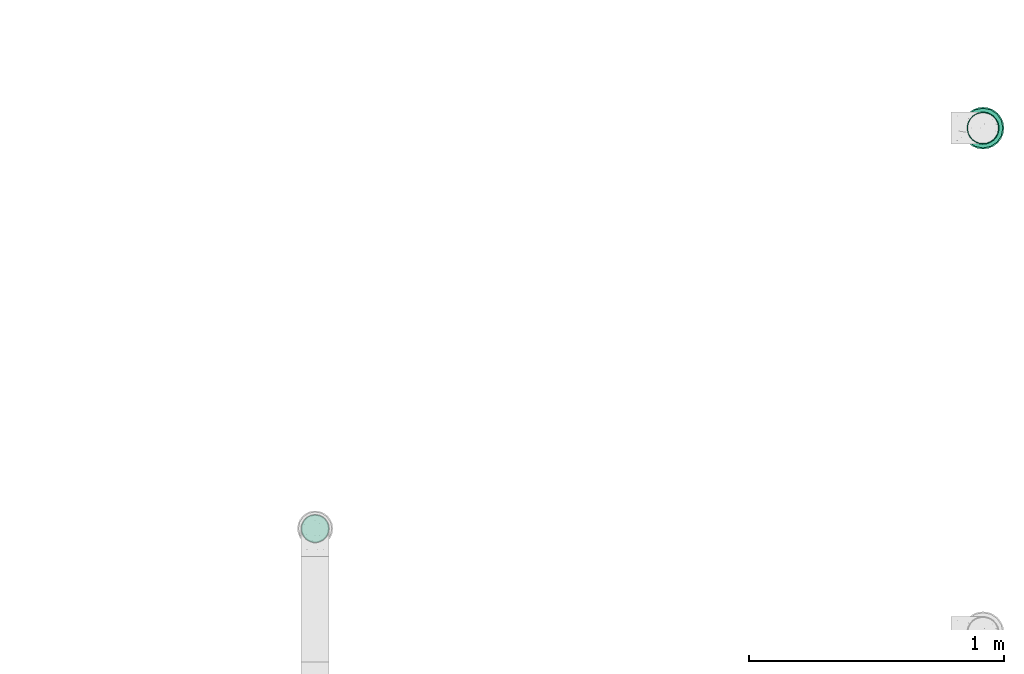
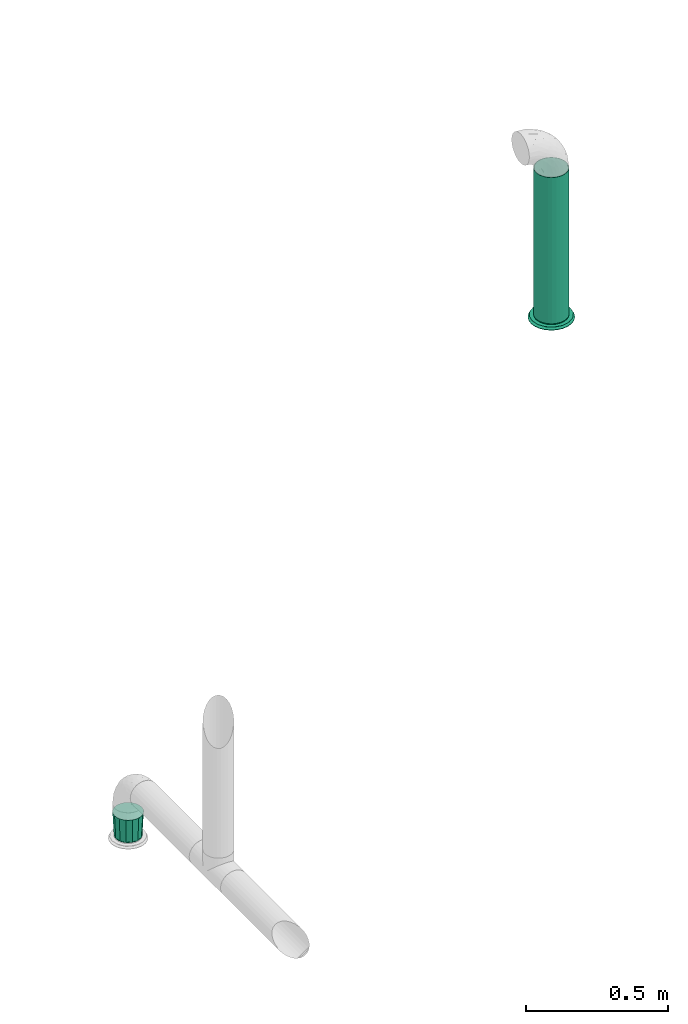
# One storey, part 94 of 103: 1 flow fitting, 1 flow segment, 1 flow terminal.
"""IFC2X3 building model written with IfcOpenShell, lengths in millimetres."""

from ifc_helpers import new_model, entity, si_unit, converted_unit, derived_unit, direction, frame, origin_with_axes, origin_2d_with_axis, place, context, subcontext, project, spatial, hollow_circle, extrude, open_shell, surface_model, source, transform, mapped, material, layer, layer_set, layer_usage, type_object, element, save


model = new_model("IFC2X3")

# Units and contexts
model_context = context("Model", 3, precision=1e-05, world=origin_with_axes(), true_north=direction((0.0, 1.0)))
body_context = subcontext(model_context, "Body", "Model", "MODEL_VIEW")
ifc_project = project(units=[si_unit("AREAUNIT", "SQUARE_METRE"), si_unit("VOLUMEUNIT", "CUBIC_METRE", prefix="DECI"), si_unit("TIMEUNIT", "SECOND"), si_unit("THERMODYNAMICTEMPERATUREUNIT", "DEGREE_CELSIUS"), si_unit("PRESSUREUNIT", "PASCAL"), si_unit("MASSUNIT", "GRAM", prefix="KILO"), si_unit("LENGTHUNIT", "METRE", prefix="MILLI"), si_unit("POWERUNIT", "WATT"), si_unit("ELECTRICCURRENTUNIT", "AMPERE"), si_unit("ELECTRICVOLTAGEUNIT", "VOLT"), derived_unit("VOLUMETRICFLOWRATEUNIT", [(si_unit("VOLUMEUNIT", "CUBIC_METRE", prefix="DECI"), 1), (si_unit("TIMEUNIT", "SECOND"), -1)]), derived_unit("LINEARVELOCITYUNIT", [(si_unit("LENGTHUNIT", "METRE"), 1), (si_unit("TIMEUNIT", "SECOND"), -1)]), derived_unit("MASSDENSITYUNIT", [(si_unit("MASSUNIT", "GRAM", prefix="KILO"), 1), (si_unit("VOLUMEUNIT", "CUBIC_METRE"), -1)]), converted_unit("PLANEANGLEUNIT", "DEGREE", entity("IfcRatioMeasure", 0.01745), si_unit("PLANEANGLEUNIT", "RADIAN"), dimensions=[0, 0, 0, 0, 0, 0, 0])], contexts=[model_context])

# Site, building, storey
site_placement = place(None, origin_with_axes())
site = spatial("IfcSite", under=ifc_project, at=site_placement, CompositionType="ELEMENT")
building_placement = place(site_placement, origin_with_axes())
building = spatial("IfcBuilding", under=site, at=building_placement, Name="mc-building", CompositionType="ELEMENT")
storey_placement = place(building_placement, frame((0.0, 0.0, 5900.0), z_axis=(0.0, 0.0, 1.0), x_axis=(1.0, 0.0, 0.0)))
storey = spatial("IfcBuildingStorey", under=building, at=storey_placement, Name="3. Korrus", CompositionType="ELEMENT", Elevation=5900.0)

# Flow terminal
air_terminal_type = type_object("IfcAirTerminalType", Name="125", PredefinedType="NOTDEFINED")
shared_shape_1 = source(origin_with_axes(), body_context, "Body", "SurfaceModel", [
    surface_model("IfcShellBasedSurfaceModel", [(11.2, 41.25, -71.4471), (11.2, 0.0, -82.5), (11.2, 21.35257, -79.68888), (11.2, 71.4471, -41.25), (11.2, 58.33631, -58.33631), (11.2, 79.68888, -21.35257), (11.2, 82.5, 0.0), (11.2, -79.68888, -21.35257), (11.2, -41.25, -71.4471), (11.2, -21.35257, -79.68888), (11.2, -58.33631, -58.33631), (11.2, -71.4471, -41.25), (11.2, 79.68888, 21.35257), (11.2, 71.4471, 41.25), (11.2, 58.33631, 58.33631), (11.2, 41.25, 71.4471), (11.2, 21.35257, 79.68888), (11.2, -58.33631, 58.33631), (11.2, -21.35257, 79.68888), (11.2, 0.0, 82.5), (11.2, -79.68888, 21.35257), (11.2, -71.4471, 41.25), (11.2, -82.5, 0.0), (11.2, -41.25, 71.4471), (9.2, 21.35257, 79.68888), (9.2, -21.35257, 79.68888), (9.2, 0.0, 82.5), (9.2, 58.33631, 58.33631), (9.2, 41.25, 71.4471), (9.2, 71.4471, 41.25), (9.2, 79.68888, 21.35257), (9.2, -58.33631, 58.33631), (9.2, -41.25, 71.4471), (9.2, -79.68888, 21.35257), (9.2, -71.4471, 41.25), (9.2, -58.33631, -58.33631), (9.2, -82.5, 0.0), (9.2, 79.68888, -21.35257), (9.2, 41.25, -71.4471), (9.2, 71.4471, -41.25), (9.2, -41.25, -71.4471), (9.2, 58.33631, -58.33631), (9.2, 0.0, -82.5), (9.2, 21.35257, -79.68888), (9.2, -71.4471, -41.25), (9.2, -79.68888, -21.35257), (9.2, -21.35257, -79.68888), (9.2, 82.5, 0.0), (9.2, 19.5, 33.77499), (9.2, 0.0, 39.0), (9.2, -19.5, 33.77499), (9.2, -39.0, 0.0), (9.2, 33.77499, 19.5), (9.2, 39.0, 0.0), (9.2, -33.77499, 19.5), (9.2, 0.0, -39.0), (9.2, -33.77499, -19.5), (9.2, -19.5, -33.77499), (9.2, 33.77499, -19.5), (9.2, 19.5, -33.77499), (6.2, 25.24133, 18.3389), (6.2, 31.2, 0.0), (6.2, 9.64133, 29.67296), (6.2, -25.24133, 18.3389), (6.2, -9.64133, 29.67296), (6.2, -31.2, 0.0), (6.2, 25.24133, -18.3389), (6.2, 9.64133, -29.67296), (6.2, -9.64133, -29.67296), (6.2, -25.24133, -18.3389), (9.2, 37.1621, -6.85914), (6.2, 28.22067, -9.16945), (9.2, 35.3242, -13.71829), (6.2, -17.44133, -24.00593), (9.2, -26.6375, -26.6375), (6.2, -28.22067, -9.16945), (9.2, -37.1621, -6.85914), (6.2, 17.44133, -24.00593), (9.2, 9.75, -36.3875), (6.2, 0.0, -29.67296), (9.2, -35.3242, -13.71829), (9.2, 26.6375, -26.6375), (9.2, -9.75, -36.3875), (9.2, -37.1621, 6.85914), (6.2, -28.22067, 9.16945), (9.2, -35.3242, 13.71829), (6.2, 17.44133, 24.00593), (9.2, 26.6375, 26.6375), (6.2, 28.22067, 9.16945), (9.2, 37.1621, 6.85914), (6.2, -17.44133, 24.00593), (9.2, -9.75, 36.3875), (6.2, 0.0, 29.67296), (9.2, 35.3242, 13.71829), (9.2, -26.6375, 26.6375), (9.2, 9.75, 36.3875), (6.2, -26.86438, 64.85634), (6.2, -49.63889, 49.63889), (6.2, -64.85634, 26.86438), (6.2, -70.2, 0.0), (6.2, 64.85634, 26.86438), (6.2, 0.0, 70.2), (6.2, 26.86438, 64.85634), (6.2, 49.63889, 49.63889), (6.2, 70.2, 0.0), (6.2, -64.85634, -26.86438), (6.2, -49.63889, -49.63889), (6.2, -26.86438, -64.85634), (6.2, 26.86438, -64.85634), (6.2, 0.0, -70.2), (6.2, 64.85634, -26.86438), (6.2, 49.63889, -49.63889), (0.0, -29.84931, 72.0626), (0.0, 0.0, 78.0), (0.0, 29.84931, 72.0626), (0.0, 55.15433, 55.15433), (0.0, 78.0, 0.0), (0.0, -55.15433, 55.15433), (0.0, -72.0626, 29.84931), (0.0, -78.0, 0.0), (0.0, 72.0626, 29.84931), (0.0, -72.0626, -29.84931), (0.0, 72.0626, -29.84931), (0.0, 55.15433, -55.15433), (0.0, 29.84931, -72.0626), (0.0, -55.15433, -55.15433), (0.0, -29.84931, -72.0626), (0.0, 0.0, -78.0), (6.2, 66.75025, -17.34304), (0.0, 63.60847, -42.50182), (6.2, 57.24762, -38.25164), (0.0, -14.92465, -75.0313), (6.2, -13.43219, -67.52817), (0.0, 42.50182, -63.60847), (6.2, 38.25164, -57.24762), (0.0, 75.0313, -14.92465), (0.0, 14.92465, -75.0313), (6.2, 13.43219, -67.52817), (0.0, -74.16695, -19.27005), (6.2, -67.52817, -13.43219), (0.0, -42.50182, -63.60847), (6.2, -38.25164, -57.24762), (0.0, -63.60847, -42.50182), (6.2, -57.24762, -38.25164), (6.2, -66.75025, 17.34304), (0.0, -63.60847, 42.50182), (6.2, -57.24762, 38.25164), (0.0, 14.92465, 75.0313), (6.2, 13.43219, 67.52817), (0.0, -42.50182, 63.60847), (6.2, -38.25164, 57.24762), (0.0, -75.0313, 14.92465), (0.0, -14.92465, 75.0313), (6.2, -13.43219, 67.52817), (0.0, 74.16695, 19.27005), (6.2, 67.52817, 13.43219), (0.0, 42.50182, 63.60847), (6.2, 38.25164, 57.24762), (0.0, 63.60847, 42.50182), (6.2, 57.24762, 38.25164), (-3.1, 16.17619, 60.37037), (-3.1, -31.25, 54.12659), (-3.1, 0.0, 62.5), (-3.1, 54.12659, 31.25), (-3.1, 31.25, 54.12659), (-3.1, 44.19417, 44.19417), (-3.1, -54.12659, -31.25), (-3.1, -54.12659, 31.25), (-3.1, -44.19417, 44.19417), (-3.1, -16.17619, 60.37037), (-3.1, -62.5, 0.0), (-3.1, -60.37037, 16.17619), (-3.1, 60.37037, 16.17619), (-3.1, 62.5, 0.0), (-3.1, 60.37037, -16.17619), (-3.1, 54.12659, -31.25), (-3.1, 44.19417, -44.19417), (-3.1, 31.25, -54.12659), (-3.1, 16.17619, -60.37037), (-3.1, -31.25, -54.12659), (-3.1, -44.19417, -44.19417), (-3.1, -60.37037, -16.17619), (-3.1, 0.0, -62.5), (-3.1, -16.17619, -60.37037), (0.0, 31.25, -54.12659), (0.0, -54.12659, -31.25), (0.0, 16.17619, -60.37037), (0.0, 54.12659, -31.25), (0.0, 44.19417, -44.19417), (0.0, 60.37037, -16.17619), (0.0, 62.5, 0.0), (0.0, 54.12659, 31.25), (0.0, 16.17619, 60.37037), (0.0, 0.0, -62.5), (0.0, -31.25, -54.12659), (0.0, -16.17619, -60.37037), (0.0, -44.19417, -44.19417), (0.0, -62.5, 0.0), (0.0, -60.37037, -16.17619), (0.0, 44.19417, 44.19417), (0.0, -54.12659, 31.25), (0.0, 31.25, 54.12659), (0.0, 0.0, 62.5), (0.0, -60.37037, 16.17619), (0.0, -31.25, 54.12659), (0.0, -44.19417, 44.19417), (0.0, -16.17619, 60.37037), (0.0, 60.37037, 16.17619), (-43.1, -14.75269, 55.05777), (-43.1, 0.0, 57.0), (-43.1, 14.75269, 55.05777), (-43.1, 28.5, 49.36345), (-43.1, 40.30508, 40.30508), (-43.1, 49.36345, 28.5), (-43.1, 55.05777, 14.75269), (-43.1, -28.5, 49.36345), (-43.1, -49.36345, 28.5), (-43.1, -40.30508, 40.30508), (-43.1, -57.0, 0.0), (-43.1, -55.05777, 14.75269), (-43.1, -40.30508, -40.30508), (-43.1, 57.0, 0.0), (-43.1, 55.05777, -14.75269), (-43.1, 28.5, -49.36345), (-43.1, 49.36345, -28.5), (-43.1, 14.75269, -55.05777), (-43.1, 40.30508, -40.30508), (-43.1, -49.36345, -28.5), (-43.1, -55.05777, -14.75269), (-43.1, -28.5, -49.36345), (-43.1, 0.0, -57.0), (-43.1, -14.75269, -55.05777), (-3.1, 57.0, 0.0), (-3.1, 14.75269, -55.05777), (-3.1, 28.5, -49.36345), (-3.1, 55.05777, -14.75269), (-3.1, 40.30508, -40.30508), (-3.1, 49.36345, -28.5), (-3.1, 55.05777, 14.75269), (-3.1, -28.5, -49.36345), (-3.1, 0.0, -57.0), (-3.1, -14.75269, -55.05777), (-3.1, -49.36345, -28.5), (-3.1, -57.0, 0.0), (-3.1, -55.05777, -14.75269), (-3.1, -40.30508, -40.30508), (-3.1, -49.36345, 28.5), (-3.1, 49.36345, 28.5), (-3.1, 40.30508, 40.30508), (-3.1, 0.0, 57.0), (-3.1, 28.5, 49.36345), (-3.1, 14.75269, 55.05777), (-3.1, -14.75269, 55.05777), (-3.1, -55.05777, 14.75269), (-3.1, -28.5, 49.36345), (-3.1, -40.30508, 40.30508)], [open_shell([[[0, 1, 2]], [[3, 0, 4]], [[5, 6, 0]], [[5, 0, 3]], [[7, 0, 6]], [[1, 8, 9]], [[1, 0, 8]], [[10, 7, 11]], [[10, 8, 0]], [[7, 10, 0]], [[6, 12, 7]], [[12, 13, 14]], [[12, 14, 15]], [[12, 16, 17]], [[16, 12, 15]], [[18, 16, 19]], [[20, 17, 21]], [[22, 7, 20]], [[17, 18, 23]], [[20, 12, 17]], [[16, 18, 17]], [[20, 7, 12]], [[24, 25, 26]], [[27, 24, 28]], [[27, 29, 30]], [[27, 30, 24]], [[31, 24, 30]], [[25, 31, 32]], [[25, 24, 31]], [[31, 33, 34]], [[31, 30, 33]], [[35, 36, 33]], [[33, 30, 37]], [[33, 37, 35]], [[38, 37, 39]], [[40, 37, 38]], [[38, 39, 41]], [[42, 38, 43]], [[36, 44, 45]], [[35, 44, 36]], [[40, 42, 46]], [[35, 37, 40]], [[38, 42, 40]], [[37, 30, 47]], [[45, 7, 36]], [[44, 11, 45]], [[8, 35, 40]], [[44, 35, 10]], [[9, 40, 46]], [[45, 11, 7]], [[7, 22, 36]], [[9, 8, 40]], [[10, 35, 8]], [[10, 11, 44]], [[1, 9, 46]], [[46, 42, 1]], [[43, 2, 42]], [[38, 0, 43]], [[3, 41, 39]], [[38, 41, 4]], [[5, 39, 37]], [[38, 4, 0]], [[0, 2, 43]], [[6, 5, 37]], [[3, 39, 5]], [[3, 4, 41]], [[47, 6, 37]], [[42, 2, 1]], [[30, 12, 47]], [[29, 13, 30]], [[15, 27, 28]], [[29, 27, 14]], [[16, 28, 24]], [[30, 13, 12]], [[12, 6, 47]], [[16, 15, 28]], [[14, 27, 15]], [[14, 13, 29]], [[19, 16, 24]], [[24, 26, 19]], [[25, 18, 26]], [[32, 23, 25]], [[21, 31, 34]], [[32, 31, 17]], [[20, 34, 33]], [[32, 17, 23]], [[23, 18, 25]], [[36, 22, 20]], [[21, 34, 20]], [[21, 17, 31]], [[33, 36, 20]], [[26, 18, 19]], [[48, 49, 50]], [[50, 51, 52]], [[50, 52, 48]], [[53, 52, 51]], [[50, 54, 51]], [[55, 51, 56]], [[55, 56, 57]], [[58, 55, 59]], [[58, 53, 55]], [[55, 53, 51]], [[60, 61, 62]], [[62, 63, 64]], [[65, 63, 62]], [[62, 61, 65]], [[66, 67, 68]], [[65, 68, 69]], [[65, 61, 68]], [[68, 61, 66]], [[61, 70, 71]], [[58, 71, 72]], [[73, 74, 69]], [[56, 75, 69]], [[76, 51, 65]], [[59, 67, 77]], [[73, 68, 57]], [[74, 73, 57]], [[67, 78, 79]], [[70, 61, 53]], [[65, 75, 76]], [[56, 80, 75]], [[66, 81, 77]], [[82, 57, 68]], [[67, 59, 78]], [[59, 77, 81]], [[81, 66, 58]], [[71, 58, 66]], [[82, 79, 55]], [[78, 55, 79]], [[68, 79, 82]], [[75, 80, 76]], [[56, 69, 74]], [[70, 72, 71]], [[65, 83, 84]], [[54, 84, 85]], [[86, 87, 60]], [[52, 88, 60]], [[89, 53, 61]], [[50, 64, 90]], [[86, 62, 48]], [[87, 86, 48]], [[64, 91, 92]], [[83, 65, 51]], [[61, 88, 89]], [[52, 93, 88]], [[63, 94, 90]], [[95, 48, 62]], [[64, 50, 91]], [[50, 90, 94]], [[94, 63, 54]], [[84, 54, 63]], [[95, 92, 49]], [[91, 49, 92]], [[62, 92, 95]], [[88, 93, 89]], [[52, 60, 87]], [[83, 85, 84]], [[96, 97, 98]], [[98, 99, 96]], [[96, 99, 100]], [[101, 96, 102]], [[100, 103, 102]], [[96, 100, 102]], [[99, 104, 100]], [[105, 106, 107]], [[105, 107, 108]], [[108, 107, 109]], [[110, 104, 111]], [[108, 111, 104]], [[99, 108, 104]], [[108, 99, 105]], [[112, 113, 114]], [[112, 114, 115]], [[116, 112, 115]], [[117, 112, 118]], [[119, 118, 112]], [[119, 112, 116]], [[116, 115, 120]], [[121, 116, 122]], [[123, 124, 122]], [[121, 122, 124]], [[125, 121, 126]], [[126, 121, 124]], [[124, 127, 126]], [[116, 121, 119]], [[110, 122, 128]], [[111, 129, 130]], [[107, 131, 132]], [[108, 133, 134]], [[104, 128, 135]], [[116, 104, 135]], [[111, 134, 123]], [[130, 122, 110]], [[136, 124, 137]], [[128, 122, 135]], [[127, 136, 109]], [[111, 123, 129]], [[119, 138, 139]], [[138, 105, 139]], [[140, 141, 106]], [[124, 108, 137]], [[139, 99, 119]], [[108, 124, 133]], [[106, 125, 140]], [[142, 143, 105]], [[123, 134, 133]], [[131, 127, 132]], [[106, 143, 125]], [[141, 126, 107]], [[126, 141, 140]], [[109, 136, 137]], [[138, 121, 105]], [[122, 130, 129]], [[125, 143, 142]], [[107, 126, 131]], [[127, 109, 132]], [[105, 121, 142]], [[98, 118, 144]], [[97, 145, 146]], [[102, 147, 148]], [[96, 149, 150]], [[99, 144, 151]], [[119, 99, 151]], [[97, 150, 117]], [[146, 118, 98]], [[152, 112, 153]], [[144, 118, 151]], [[113, 152, 101]], [[97, 117, 145]], [[116, 154, 155]], [[154, 100, 155]], [[156, 157, 103]], [[112, 96, 153]], [[155, 104, 116]], [[96, 112, 149]], [[103, 115, 156]], [[158, 159, 100]], [[117, 150, 149]], [[147, 113, 148]], [[103, 159, 115]], [[157, 114, 102]], [[114, 157, 156]], [[101, 152, 153]], [[154, 120, 100]], [[118, 146, 145]], [[115, 159, 158]], [[102, 114, 147]], [[113, 101, 148]], [[100, 120, 158]], [[160, 161, 162]], [[163, 160, 164]], [[161, 160, 163]], [[163, 164, 165]], [[163, 166, 167]], [[161, 167, 168]], [[161, 169, 162]], [[167, 170, 171]], [[167, 161, 163]], [[166, 170, 167]], [[163, 172, 173]], [[173, 174, 175]], [[173, 175, 176]], [[177, 178, 173]], [[177, 173, 176]], [[173, 178, 179]], [[166, 179, 180]], [[181, 170, 166]], [[179, 182, 183]], [[166, 163, 179]], [[182, 179, 178]], [[163, 173, 179]], [[184, 185, 186]], [[187, 184, 188]], [[187, 189, 190]], [[184, 187, 191]], [[192, 185, 184]], [[193, 194, 195]], [[193, 186, 194]], [[194, 185, 196]], [[186, 185, 194]], [[185, 197, 198]], [[190, 191, 187]], [[191, 192, 184]], [[192, 191, 199]], [[192, 200, 185]], [[192, 199, 201]], [[202, 200, 192]], [[197, 200, 203]], [[185, 200, 197]], [[200, 204, 205]], [[202, 204, 200]], [[202, 206, 204]], [[191, 190, 207]], [[172, 207, 173]], [[163, 191, 172]], [[201, 165, 164]], [[163, 165, 199]], [[192, 164, 160]], [[172, 191, 207]], [[207, 190, 173]], [[192, 201, 164]], [[199, 165, 201]], [[199, 191, 163]], [[202, 192, 160]], [[160, 162, 202]], [[169, 206, 162]], [[161, 204, 169]], [[200, 168, 167]], [[161, 168, 205]], [[203, 167, 171]], [[161, 205, 204]], [[204, 206, 169]], [[197, 203, 171]], [[200, 167, 203]], [[200, 205, 168]], [[170, 197, 171]], [[162, 206, 202]], [[181, 198, 170]], [[166, 185, 181]], [[194, 180, 179]], [[166, 180, 196]], [[195, 179, 183]], [[181, 185, 198]], [[198, 197, 170]], [[195, 194, 179]], [[196, 180, 194]], [[196, 185, 166]], [[193, 195, 183]], [[183, 182, 193]], [[178, 186, 182]], [[177, 184, 178]], [[187, 176, 175]], [[177, 176, 188]], [[189, 175, 174]], [[177, 188, 184]], [[184, 186, 178]], [[190, 189, 174]], [[187, 175, 189]], [[187, 188, 176]], [[173, 190, 174]], [[182, 186, 193]], [[208, 209, 210]], [[211, 208, 210]], [[212, 213, 214]], [[212, 214, 211]], [[208, 211, 214]], [[215, 216, 217]], [[216, 215, 208]], [[216, 218, 219]], [[216, 208, 214]], [[216, 220, 218]], [[216, 214, 221]], [[220, 216, 222]], [[223, 222, 224]], [[223, 225, 222]], [[223, 224, 226]], [[220, 222, 225]], [[218, 227, 228]], [[220, 227, 218]], [[229, 230, 231]], [[229, 220, 225]], [[230, 229, 225]], [[216, 221, 222]], [[232, 233, 234]], [[235, 234, 236]], [[235, 232, 234]], [[235, 236, 237]], [[238, 239, 233]], [[240, 239, 241]], [[240, 233, 239]], [[242, 243, 244]], [[245, 239, 246]], [[242, 245, 243]], [[238, 233, 232]], [[238, 247, 248]], [[238, 248, 249]], [[250, 251, 249]], [[250, 249, 248]], [[238, 249, 252]], [[243, 246, 253]], [[245, 246, 243]], [[246, 254, 255]], [[254, 246, 252]], [[238, 252, 246]], [[246, 239, 238]], [[214, 238, 221]], [[213, 247, 214]], [[250, 212, 211]], [[213, 212, 248]], [[251, 211, 210]], [[214, 247, 238]], [[238, 232, 221]], [[251, 250, 211]], [[248, 212, 250]], [[248, 247, 213]], [[249, 251, 210]], [[210, 209, 249]], [[254, 215, 217]], [[246, 216, 219]], [[217, 216, 255]], [[253, 219, 218]], [[208, 254, 252]], [[208, 215, 254]], [[252, 249, 208]], [[217, 255, 254]], [[216, 246, 255]], [[253, 246, 219]], [[218, 243, 253]], [[208, 249, 209]], [[228, 244, 218]], [[227, 242, 228]], [[239, 220, 229]], [[227, 220, 245]], [[241, 229, 231]], [[228, 242, 244]], [[244, 243, 218]], [[241, 239, 229]], [[245, 220, 239]], [[245, 242, 227]], [[240, 241, 231]], [[231, 230, 240]], [[233, 230, 225]], [[234, 225, 223]], [[237, 224, 222]], [[221, 235, 222]], [[225, 234, 233]], [[234, 223, 226]], [[234, 226, 236]], [[226, 224, 236]], [[224, 237, 236]], [[235, 237, 222]], [[221, 232, 235]], [[230, 233, 240]]])]),
])
flow_terminal_placement = place(storey_placement, frame((36404.9937, 6304.03427, 2460.0), z_axis=(1.0, 0.0, 0.0), x_axis=(0.0, 0.0, -1.0)))
element("IfcFlowTerminal", 1, at=flow_terminal_placement, inside=storey, type_object=air_terminal_type, Name="125", context=body_context, shape_type="MappedRepresentation", body=[
    mapped(shared_shape_1, transform((0.0, 0.0, 0.0), scale=1.0)),
])

# Flow fitting
duct_fitting_type = type_object("IfcDuctFittingType", PredefinedType="TRANSITION")
shared_shape_2 = source(origin_with_axes(), body_context, "Body", "SurfaceModel", [
    surface_model("IfcShellBasedSurfaceModel", [(0.0, 12.94095, 48.29629), (0.0, -35.35534, 35.35534), (0.0, 0.0, 50.0), (0.0, 35.35534, 35.35534), (0.0, 25.0, 43.30127), (0.0, 43.30127, 25.0), (0.0, 48.29629, 12.94095), (0.0, -12.94095, 48.29629), (0.0, -25.0, 43.30127), (0.0, -48.29629, 12.94095), (0.0, -43.30127, 25.0), (0.0, -25.0, -43.30127), (0.0, -48.29629, -12.94095), (0.0, -50.0, 0.0), (0.0, 48.29629, -12.94095), (0.0, 12.94095, -48.29629), (0.0, 43.30127, -25.0), (0.0, 35.35534, -35.35534), (0.0, 25.0, -43.30127), (0.0, -35.35534, -35.35534), (0.0, -43.30127, -25.0), (0.0, -12.94095, -48.29629), (0.0, 0.0, -50.0), (0.0, 50.0, 0.0), (100.0, -55.0, 0.0), (100.0, -12.23865, 53.62104), (100.0, -34.29194, 43.00073), (100.0, 49.55329, -23.86361), (100.0, 12.23865, 53.62104), (100.0, 34.29194, 43.00073), (100.0, 55.0, 0.0), (100.0, 49.55329, 23.86361), (100.0, -49.55329, 23.86361), (100.0, 12.23865, -53.62104), (100.0, -49.55329, -23.86361), (100.0, -34.29194, -43.00073), (100.0, 34.29194, -43.00073), (100.0, -12.23865, -53.62104), (0.0, 11.12605, 48.7464), (0.0, -11.12605, 48.7464), (0.0, 31.17449, 39.09157), (0.0, -45.04844, -21.69419), (0.0, -45.04844, 21.69419), (0.0, -31.17449, 39.09157), (0.0, 45.04844, 21.69419), (0.0, 45.04844, -21.69419), (0.0, 31.17449, -39.09157), (0.0, -31.17449, -39.09157), (0.0, -11.12605, -48.7464), (0.0, 11.12605, -48.7464), (0.0, -47.52422, -10.84709), (100.0, -41.92261, -33.43217), (0.0, -38.11147, -30.39288), (100.0, 41.92261, -33.43217), (0.0, 38.11147, -30.39288), (0.0, -21.15027, -43.91899), (100.0, -23.2653, -48.31088), (100.0, -52.32388, -11.72483), (100.0, 0.0, -53.62104), (0.0, 0.0, -48.7464), (100.0, 23.2653, -48.31088), (0.0, 21.15027, -43.91899), (100.0, 52.32388, -11.72483), (0.0, 47.52422, -10.84709), (0.0, 47.52422, 10.84709), (100.0, 41.92261, 33.43217), (0.0, 38.11147, 30.39288), (100.0, -41.92261, 33.43217), (0.0, -38.11147, 30.39288), (0.0, 21.15027, 43.91899), (100.0, 23.2653, 48.31088), (100.0, 52.32388, 11.72483), (100.0, 0.0, 53.62104), (0.0, 0.0, 48.7464), (100.0, -23.2653, 48.31088), (0.0, -21.15027, 43.91899), (100.0, -52.32388, 11.72483), (0.0, -47.52422, 10.84709), (100.0, 27.5, -47.63139), (100.0, 0.0, -55.0), (100.0, 14.23505, -53.12592), (100.0, 38.89087, -38.89087), (100.0, -27.5, -47.63139), (100.0, 47.63139, -27.5), (100.0, 53.12592, -14.23505), (100.0, -14.23505, -53.12592), (100.0, -47.63139, -27.5), (100.0, -38.89087, -38.89087), (100.0, -53.12592, -14.23505), (100.0, 53.12592, 14.23505), (100.0, 47.63139, 27.5), (100.0, 27.5, 47.63139), (100.0, 38.89087, 38.89087), (100.0, 14.23505, 53.12592), (100.0, 0.0, 55.0), (100.0, -47.63139, 27.5), (100.0, -53.12592, 14.23505), (100.0, -27.5, 47.63139), (100.0, -38.89087, 38.89087), (100.0, -14.23505, 53.12592), (98.0, 0.0, 55.0), (98.0, 14.23505, 53.12592), (98.0, 27.5, 47.63139), (98.0, 38.89087, 38.89087), (98.0, 47.63139, 27.5), (98.0, -47.63139, 27.5), (98.0, 53.12592, -14.23505), (98.0, -27.5, 47.63139), (98.0, -14.23505, 53.12592), (98.0, -38.89087, 38.89087), (98.0, -55.0, 0.0), (98.0, -53.12592, 14.23505), (98.0, 53.12592, 14.23505), (98.0, 47.63139, -27.5), (98.0, -27.5, -47.63139), (98.0, 0.0, -55.0), (98.0, 38.89087, -38.89087), (98.0, 27.5, -47.63139), (98.0, 14.23505, -53.12592), (98.0, -47.63139, -27.5), (98.0, -38.89087, -38.89087), (98.0, -53.12592, -14.23505), (98.0, -14.23505, -53.12592), (98.0, 55.0, 0.0), (2.0, 12.94095, -48.29629), (2.0, 25.0, -43.30127), (2.0, 35.35534, -35.35534), (2.0, 43.30127, -25.0), (2.0, 48.29629, -12.94095), (2.0, 0.0, -50.0), (2.0, 50.0, 0.0), (2.0, -25.0, -43.30127), (2.0, -12.94095, -48.29629), (2.0, -35.35534, -35.35534), (2.0, -48.29629, -12.94095), (2.0, -43.30127, -25.0), (2.0, -48.29629, 12.94095), (2.0, 48.29629, 12.94095), (2.0, 43.30127, 25.0), (2.0, 35.35534, 35.35534), (2.0, -35.35534, 35.35534), (2.0, 12.94095, 48.29629), (2.0, 25.0, 43.30127), (2.0, 0.0, 50.0), (2.0, -43.30127, 25.0), (2.0, -50.0, 0.0), (2.0, -12.94095, 48.29629), (2.0, -25.0, 43.30127)], [open_shell([[[0, 1, 2]], [[3, 0, 4]], [[3, 5, 6]], [[0, 3, 1]], [[6, 1, 3]], [[7, 1, 8]], [[7, 2, 1]], [[1, 9, 10]], [[9, 1, 11]], [[12, 13, 9]], [[11, 1, 6]], [[6, 14, 11]], [[15, 14, 16]], [[17, 18, 15]], [[17, 15, 16]], [[11, 14, 15]], [[12, 19, 20]], [[19, 12, 11]], [[15, 21, 11]], [[12, 9, 11]], [[22, 21, 15]], [[14, 6, 23]], [[24, 25, 26]], [[25, 27, 28]], [[29, 28, 27]], [[27, 30, 31]], [[31, 29, 27]], [[24, 26, 32]], [[33, 24, 34]], [[33, 34, 35]], [[36, 27, 33]], [[33, 27, 24]], [[35, 37, 33]], [[24, 27, 25]], [[38, 23, 39]], [[40, 23, 38]], [[41, 42, 43]], [[41, 13, 42]], [[23, 43, 39]], [[40, 44, 23]], [[41, 23, 45]], [[41, 45, 46]], [[47, 41, 48]], [[49, 48, 41]], [[41, 46, 49]], [[23, 41, 43]], [[34, 50, 41]], [[47, 51, 52]], [[45, 27, 53]], [[36, 54, 53]], [[55, 48, 56]], [[34, 57, 50]], [[57, 13, 50]], [[13, 57, 24]], [[55, 35, 47]], [[35, 51, 47]], [[51, 41, 52]], [[58, 59, 49]], [[60, 61, 46]], [[37, 59, 58]], [[62, 63, 23]], [[35, 55, 56]], [[23, 30, 62]], [[53, 54, 45]], [[48, 37, 56]], [[33, 49, 61]], [[49, 33, 58]], [[54, 36, 46]], [[63, 27, 45]], [[34, 41, 51]], [[33, 61, 60]], [[48, 59, 37]], [[27, 63, 62]], [[46, 36, 60]], [[31, 64, 44]], [[40, 65, 66]], [[42, 32, 67]], [[26, 68, 67]], [[69, 38, 70]], [[31, 71, 64]], [[71, 23, 64]], [[23, 71, 30]], [[69, 29, 40]], [[29, 65, 40]], [[65, 44, 66]], [[72, 73, 39]], [[74, 75, 43]], [[28, 73, 72]], [[76, 77, 13]], [[29, 69, 70]], [[13, 24, 76]], [[67, 68, 42]], [[38, 28, 70]], [[25, 39, 75]], [[39, 25, 72]], [[68, 26, 43]], [[77, 32, 42]], [[31, 44, 65]], [[25, 75, 74]], [[38, 73, 28]], [[32, 77, 76]], [[43, 26, 74]], [[78, 79, 80]], [[81, 82, 78]], [[82, 83, 84]], [[81, 83, 82]], [[30, 82, 84]], [[79, 82, 85]], [[79, 78, 82]], [[82, 86, 87]], [[82, 30, 86]], [[24, 88, 86]], [[86, 30, 89]], [[90, 24, 89]], [[91, 90, 92]], [[91, 93, 94]], [[90, 91, 24]], [[94, 95, 91]], [[24, 95, 96]], [[24, 91, 95]], [[94, 97, 98]], [[98, 95, 94]], [[97, 94, 99]], [[89, 24, 86]], [[100, 101, 102]], [[100, 102, 103]], [[100, 104, 105]], [[104, 100, 103]], [[106, 105, 104]], [[100, 107, 108]], [[100, 109, 107]], [[105, 110, 111]], [[109, 100, 105]], [[105, 106, 110]], [[106, 104, 112]], [[106, 113, 110]], [[113, 114, 110]], [[115, 116, 117]], [[113, 116, 115]], [[117, 118, 115]], [[119, 114, 120]], [[121, 110, 119]], [[114, 115, 122]], [[119, 110, 114]], [[115, 114, 113]], [[123, 106, 112]], [[121, 88, 110]], [[119, 86, 121]], [[82, 120, 114]], [[119, 120, 87]], [[85, 114, 122]], [[121, 86, 88]], [[88, 24, 110]], [[85, 82, 114]], [[87, 120, 82]], [[87, 86, 119]], [[79, 85, 122]], [[122, 115, 79]], [[118, 80, 115]], [[117, 78, 118]], [[83, 116, 113]], [[117, 116, 81]], [[84, 113, 106]], [[117, 81, 78]], [[78, 80, 118]], [[30, 84, 106]], [[83, 113, 84]], [[83, 81, 116]], [[123, 30, 106]], [[115, 80, 79]], [[112, 89, 123]], [[104, 90, 112]], [[91, 103, 102]], [[104, 103, 92]], [[93, 102, 101]], [[112, 90, 89]], [[89, 30, 123]], [[93, 91, 102]], [[92, 103, 91]], [[92, 90, 104]], [[94, 93, 101]], [[101, 100, 94]], [[108, 99, 100]], [[107, 97, 108]], [[95, 109, 105]], [[107, 109, 98]], [[96, 105, 111]], [[107, 98, 97]], [[97, 99, 108]], [[24, 96, 111]], [[95, 105, 96]], [[95, 98, 109]], [[110, 24, 111]], [[100, 99, 94]], [[124, 125, 126]], [[124, 126, 127]], [[124, 128, 129]], [[128, 124, 127]], [[129, 128, 130]], [[129, 131, 132]], [[129, 130, 131]], [[133, 134, 135]], [[134, 133, 131]], [[131, 136, 134]], [[131, 130, 137]], [[137, 138, 139]], [[140, 137, 139]], [[140, 139, 141]], [[141, 139, 142]], [[140, 141, 143]], [[136, 140, 144]], [[145, 134, 136]], [[140, 146, 147]], [[131, 140, 136]], [[143, 146, 140]], [[131, 137, 140]], [[12, 134, 13]], [[20, 135, 12]], [[131, 19, 11]], [[20, 19, 133]], [[132, 11, 21]], [[12, 135, 134]], [[134, 145, 13]], [[132, 131, 11]], [[133, 19, 131]], [[133, 135, 20]], [[129, 132, 21]], [[21, 22, 129]], [[15, 124, 22]], [[18, 125, 15]], [[127, 17, 16]], [[18, 17, 126]], [[128, 16, 14]], [[18, 126, 125]], [[125, 124, 15]], [[130, 128, 14]], [[127, 16, 128]], [[127, 126, 17]], [[23, 130, 14]], [[22, 124, 129]], [[6, 137, 23]], [[5, 138, 6]], [[142, 3, 4]], [[5, 3, 139]], [[141, 4, 0]], [[6, 138, 137]], [[137, 130, 23]], [[141, 142, 4]], [[139, 3, 142]], [[139, 138, 5]], [[143, 141, 0]], [[0, 2, 143]], [[7, 146, 2]], [[8, 147, 7]], [[144, 1, 10]], [[8, 1, 140]], [[136, 10, 9]], [[8, 140, 147]], [[147, 146, 7]], [[145, 136, 9]], [[144, 10, 136]], [[144, 140, 1]], [[13, 145, 9]], [[2, 146, 143]]])]),
])
flow_fitting_placement = place(storey_placement, frame((33781.67179, 4730.85862, 2103.1), z_axis=(0.0, -1.0, 0.0), x_axis=(0.0, 0.0, 1.0)))
element("IfcFlowFitting", 2, at=flow_fitting_placement, inside=storey, type_object=duct_fitting_type, context=body_context, shape_type="MappedRepresentation", body=[
    mapped(shared_shape_2, transform((0.0, 0.0, 0.0), scale=1.0)),
])

# Flow segment
ifc_material = material(Name="FZ1")
ifc_layer = layer(ifc_material, 0.0)
ifc_layer_set = layer_set([ifc_layer], Name="FZ1")
ifc_layer_usage = layer_usage(ifc_layer_set, "AXIS1", "POSITIVE", 0.0)
duct_segment_type = type_object("IfcDuctSegmentType", Name="Safe", PredefinedType="RIGIDSEGMENT")
shared_shape_3 = source(origin_with_axes(), body_context, "Body", "SweptSolid", [
    extrude(hollow_circle(Radius=62.5, WallThickness=2.0, at=origin_2d_with_axis()), frame((0.0, 0.0, 0.0), z_axis=(1.0, 0.0, 0.0), x_axis=(0.0, 1.0, 0.0)), (0.0, 0.0, 1.0), 626.9),
])
flow_segment_placement = place(storey_placement, frame((36404.9937, 6304.03427, 2463.1), z_axis=(1.0, 0.0, 0.0), x_axis=(0.0, 0.0, 1.0)))
element("IfcFlowSegment", 3, at=flow_segment_placement, inside=storey, type_object=duct_segment_type, material=ifc_layer_usage, Name="Safe", context=body_context, shape_type="MappedRepresentation", body=[
    mapped(shared_shape_3, transform((0.0, 0.0, 0.0), scale=1.0)),
])

save(model, "model.ifc")
